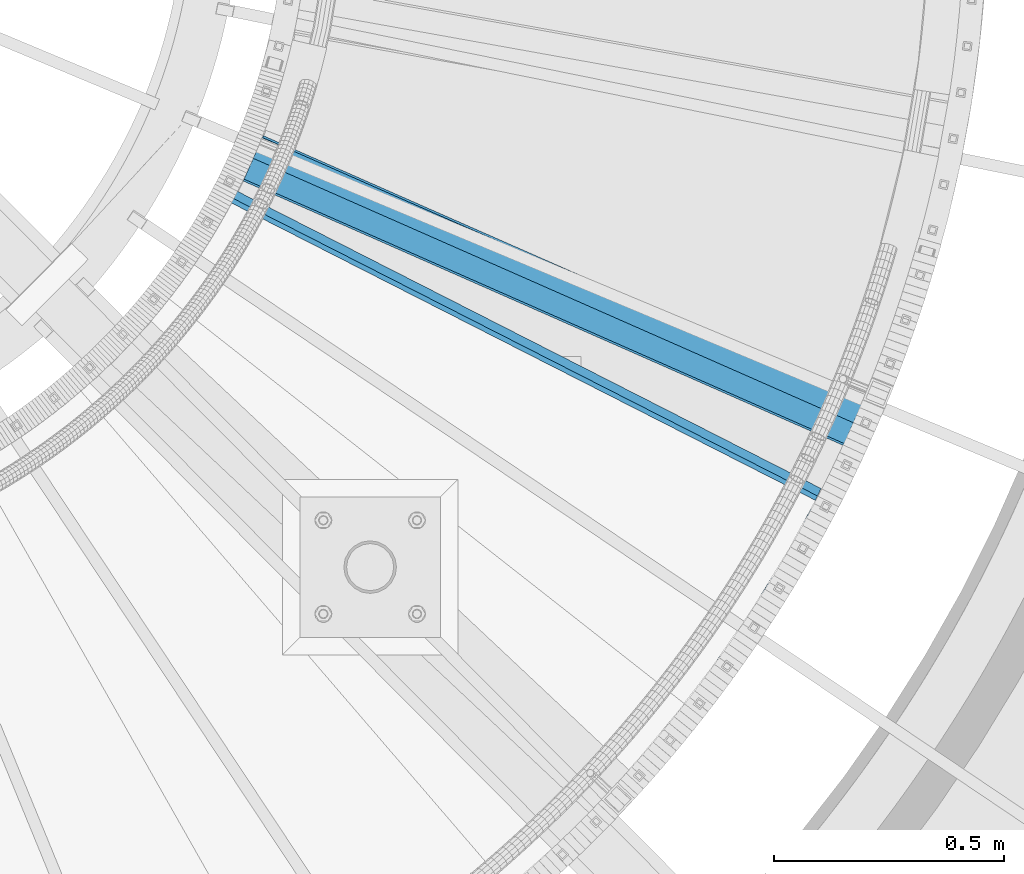
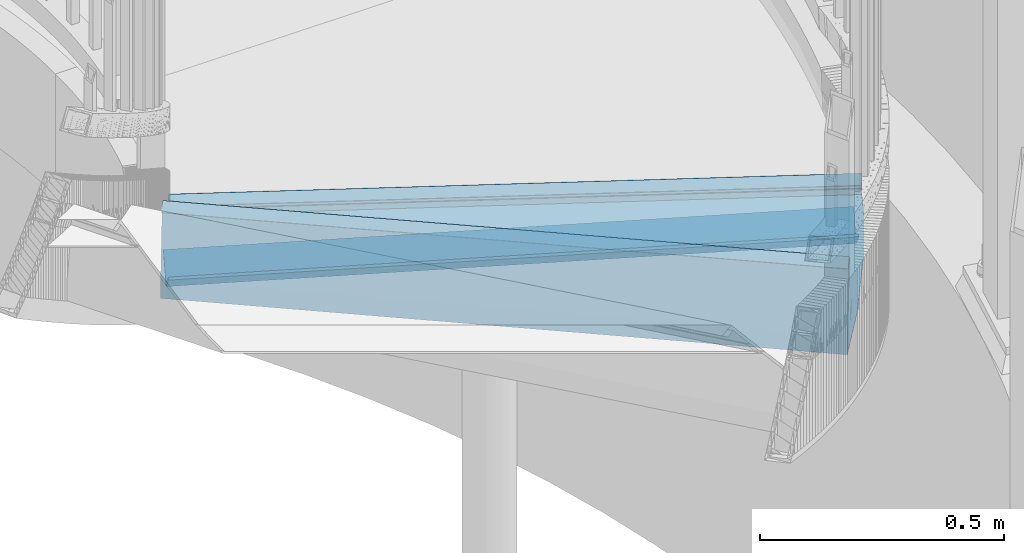
# One storey, part 359 of 975: 3 beams.
"""IFC2X3 building model written with IfcOpenShell, lengths in millimetres."""

from ifc_helpers import new_model, si_unit, frame, origin_with_axes, place, context, subcontext, project, spatial, faceted_brep, material, type_object, element, save


model = new_model("IFC2X3")

# Units and contexts
model_context = context("Model", 3, precision=1e-05, world=origin_with_axes())
body_context = subcontext(model_context, "Body", "Model", "MODEL_VIEW")
ifc_project = project(units=[si_unit("LENGTHUNIT", "METRE", prefix="MILLI"), si_unit("AREAUNIT", "SQUARE_METRE"), si_unit("VOLUMEUNIT", "CUBIC_METRE"), si_unit("MASSUNIT", "GRAM", prefix="KILO"), si_unit("TIMEUNIT", "SECOND"), si_unit("PLANEANGLEUNIT", "RADIAN"), si_unit("SOLIDANGLEUNIT", "STERADIAN"), si_unit("THERMODYNAMICTEMPERATUREUNIT", "DEGREE_CELSIUS"), si_unit("LUMINOUSINTENSITYUNIT", "LUMEN")], contexts=[model_context])

# Site, building, storey
site_placement = place(None, origin_with_axes())
site = spatial("IfcSite", under=ifc_project, at=site_placement, CompositionType="ELEMENT")
building_placement = place(site_placement, origin_with_axes())
building = spatial("IfcBuilding", under=site, at=building_placement, Name="Undefined", CompositionType="ELEMENT")
storey_placement = place(building_placement, origin_with_axes())
storey = spatial("IfcBuildingStorey", under=building, at=storey_placement, Name="Undefined", CompositionType="ELEMENT", Elevation=0.0)

# Beams
ifc_material = material(Name="STEEL/A36")
beam_type_1 = type_object("IfcBeamType", Name="L3X3X1/4", PredefinedType="NOTDEFINED")
beam_1_placement = place(storey_placement, frame((36035.9424761257, 2829.87017556571, 2078.30987194315), z_axis=(0.285096956799636, 0.647085562686452, 0.70710678103547), x_axis=(0.915117178571485, -0.403187982811201, 0.0)))
element("IfcBeam", 1, at=beam_1_placement, inside=storey, type_object=beam_type_1, material=ifc_material, Name="ANGLE", ObjectType="L3X3X1/4", context=body_context, shape_type="Brep", body=[
    faceted_brep([(-6.18456397205591e-11, 38.0999999999876, -38.1000000000258), (1.45519152283669e-10, 38.1000000000295, 38.1000000000386), (1423.28392836863, 38.0999999996639, 38.0999999996748), (1423.28392836842, 38.0999999996202, -38.1000000003896), (1.41881173476577e-10, 31.7500000000291, 38.1000000000404), (1423.28392836862, 31.7499999996635, 38.0999999996766), (-5.45696821063757e-11, 31.7499999999909, -31.75000000002), (1423.28392836843, 31.7499999996235, -31.7500000003856), (-1.23691279441118e-10, -38.100000000024, -31.7500000000309), (1423.28392836836, -38.1000000003878, -31.7500000003965), (-1.41881173476577e-10, -38.1000000000258, -38.1000000000386), (1423.28392836833, -38.1000000003933, -38.100000000406)], [[[0, 1, 2, 3]], [[1, 4, 5, 2]], [[4, 6, 7, 5]], [[6, 8, 9, 7]], [[8, 10, 11, 9]], [[10, 0, 3, 11]], [[5, 7, 9, 11, 3, 2]], [[10, 8, 6, 4, 1, 0]]]),
])
beam_type_2 = type_object("IfcBeamType", PredefinedType="NOTDEFINED")
beam_2_placement = place(storey_placement, frame((36678.5168466865, 2394.78762838428, 2292.31695574218), z_axis=(0.891119419256446, -0.453768862554554, -3.7780637285323e-10), x_axis=(0.320863040063131, 0.630116584124128, 0.707106781139304)))
element("IfcBeam", 2, at=beam_2_placement, inside=storey, type_object=beam_type_2, material=ifc_material, Name="TREAD", context=body_context, shape_type="Brep", body=[
    faceted_brep([(15.8745748282345, -1.58750017901184, -768.605275732323), (-120.373022220361, -103.767492245748, -768.533065418116), (-120.373022221533, -103.76749224318, 653.560250726816), (15.8745748038546, -1.5875001784334, 653.330368544412), (-1.58015609486029e-08, -1.58750000031432, -768.571627720263), (-1.96268956642598e-08, -1.58749999973588, 653.437487347819), (1.99397618416697e-08, 1.58749999968677, -768.564897939472), (1.61144271260127e-08, 1.58750000026703, 653.458911680114), (25.4000001865188, 1.58749971376164, -768.618736200977), (25.4000001621371, 1.5874997143419, 653.28751700326), (-118.287540216395, -106.172138302336, -768.542582766611), (-118.287540217565, -106.172138299769, 653.529952144057), (-149.718432901582, -137.603030988068, 653.529952160912), (-149.718433278054, -137.603031368186, -768.542582749815), (-151.963497308469, -135.357967338068, -768.533065401232), (-151.963496931994, -135.357966957941, 653.560250743751)], [[[0, 1, 2, 3]], [[4, 0, 3, 5]], [[6, 4, 5, 7]], [[8, 6, 7, 9]], [[10, 8, 9, 11]], [[10, 11, 12, 13]], [[1, 0, 4, 6, 8, 10, 13, 14]], [[2, 1, 14, 15]], [[11, 9, 7, 5, 3, 2, 15, 12]], [[14, 13, 12, 15]]]),
])
beam_type_3 = type_object("IfcBeamType", PredefinedType="NOTDEFINED")
beam_3_placement = place(storey_placement, frame((36446.406027205, 2037.48080485453, 2470.11695574218), z_axis=(0.786398966874614, -0.617718920625344, -5.6922408475657e-10), x_axis=(0.436793238036573, 0.556068042046603, 0.707106781059257)))
element("IfcBeam", 3, at=beam_3_placement, inside=storey, type_object=beam_type_3, material=ifc_material, Name="TREAD", context=body_context, shape_type="Brep", body=[
    faceted_brep([(25.4000001621371, 1.5874997143419, 653.28751700326), (1.61144271260127e-08, 1.58750000026703, 653.458911680114), (-1.96268956642598e-08, -1.58749999973588, 653.437487347819), (15.8745748038546, -1.5875001784334, 653.330368544412), (-120.373022221533, -103.76749224318, 653.560250726816), (-154.208562872085, -137.603032237963, 653.560249286144), (-49.0005534961238, -242.811041643061, 652.140399877677), (-46.7554894721361, -240.565977619684, 652.140399877557), (-149.718432901582, -137.603030988068, 653.529952160912), (-118.287540217565, -106.172138299769, 653.529952144057), (82.2634121742994, -374.075007349978, 638.193006315465), (84.508476198167, -371.829943326711, 638.193006315345), (212.601306559884, -504.412901568812, 612.134347567509), (214.846370562875, -502.167837565145, 612.134347570151), (261.055176792581, -530.596712595621, 601.111823144849), (259.197053542079, -528.103470062568, 601.754434690294), (248.701623596196, -536.023091227627, 602.134831213494), (248.362633442506, -540.174228440612, 601.571851715846), (250.921725105154, -538.24319290819, 601.479100122608), (25.4000001865188, 1.58749971376164, -768.618736200977), (-118.287540216395, -106.172138302336, -768.542582766611), (-149.718433278054, -137.603031368186, -768.542582749815), (-92.8426928760819, -194.478774201189, -768.783692225286), (-95.087756899542, -196.723838224048, -768.783692225159), (-154.208562871598, -137.603032235413, -768.533065523057), (-120.373022220361, -103.767492245748, -768.533065418116), (15.8745748282345, -1.58750017901184, -768.605275732323), (-1.58015609486029e-08, -1.58750000031432, -768.571627720263), (1.99397618416697e-08, 1.58749999968677, -768.564897939472), (-21.2434099455131, -266.078057151808, -776.330856581004), (-23.4884739689005, -268.323121174595, -776.330856580884), (49.7927349215133, -337.114201961485, -791.08236047571), (47.5476709198538, -339.35926596382, -791.082360478347), (66.437802308692, -335.979336534963, -793.502619428495), (56.3071310127107, -343.628597994977, -793.115412720523), (53.7487404151489, -345.560335457225, -793.01762786691), (54.0919957188744, -341.413461775162, -792.424099714608), (64.5845451579717, -333.490960101732, -792.825137753654)], [[[0, 1, 2, 3, 4, 5, 6, 7, 8, 9]], [[7, 6, 10, 11]], [[11, 10, 12, 13]], [[14, 15, 16, 13, 12, 17, 18]], [[19, 20, 21, 22, 23, 24, 25, 26, 27, 28]], [[29, 30, 23, 22]], [[31, 32, 30, 29]], [[33, 34, 35, 32, 31, 36, 37]], [[34, 33, 14, 18]], [[35, 34, 18, 17]], [[10, 6, 5, 24, 23, 30, 32, 35, 17, 12]], [[25, 24, 5, 4]], [[26, 25, 4, 3]], [[27, 26, 3, 2]], [[28, 27, 2, 1]], [[19, 28, 1, 0]], [[20, 19, 0, 9]], [[20, 9, 8, 21]], [[36, 31, 29, 22, 21, 8, 7, 11, 13, 16]], [[37, 36, 16, 15]], [[33, 37, 15, 14]]]),
])

save(model, "model.ifc")
